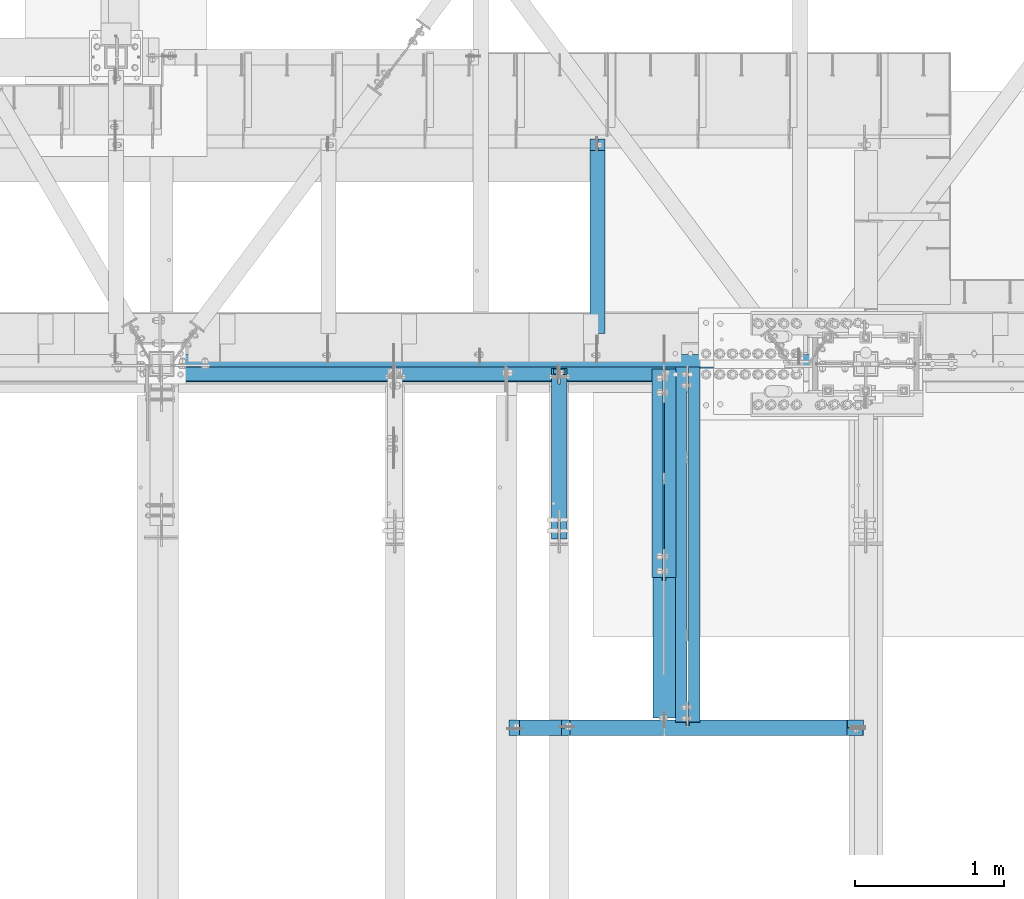
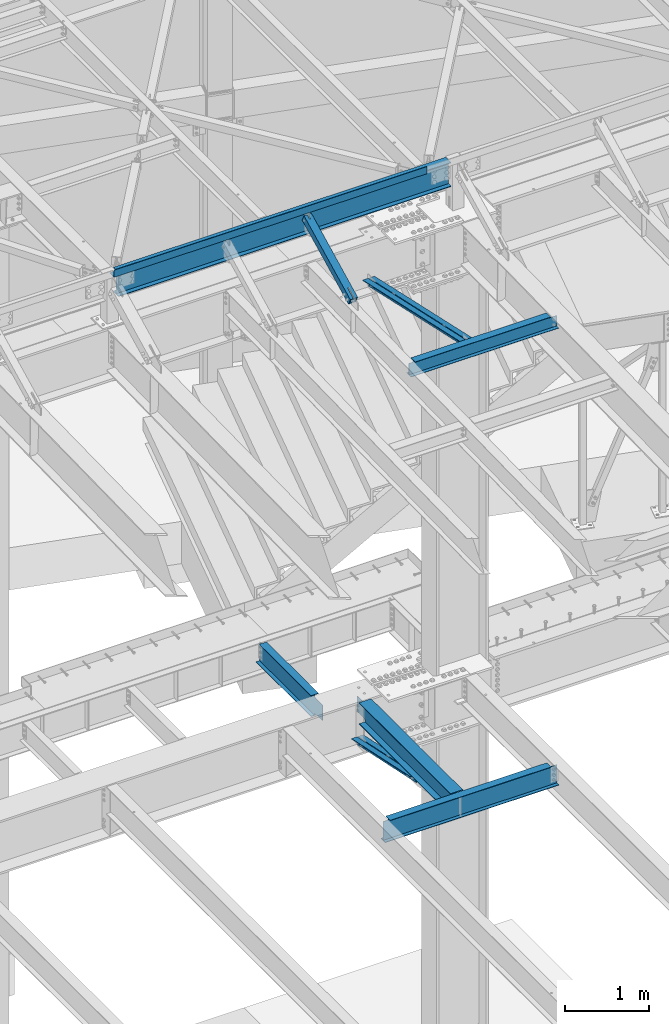
# One storey, part 1145 of 1763: 10 beams, 1 member, 8 elements without a shape of their own.
"""IFC2X3 building model written with IfcOpenShell, lengths in millimetres."""

from ifc_helpers import new_model, si_unit, frame, origin_with_axes, place, context, subcontext, project, spatial, faceted_brep, material, type_object, element, aggregate, save


model = new_model("IFC2X3")

# Units and contexts
model_context = context("Model", 3, precision=1e-05, world=origin_with_axes())
body_context = subcontext(model_context, "Body", "Model", "MODEL_VIEW")
ifc_project = project(units=[si_unit("LENGTHUNIT", "METRE", prefix="MILLI"), si_unit("AREAUNIT", "SQUARE_METRE"), si_unit("VOLUMEUNIT", "CUBIC_METRE"), si_unit("MASSUNIT", "GRAM", prefix="KILO"), si_unit("TIMEUNIT", "SECOND"), si_unit("PLANEANGLEUNIT", "RADIAN"), si_unit("SOLIDANGLEUNIT", "STERADIAN"), si_unit("THERMODYNAMICTEMPERATUREUNIT", "DEGREE_CELSIUS"), si_unit("LUMINOUSINTENSITYUNIT", "LUMEN")], contexts=[model_context])

# Site, building, storey
site_placement = place(None, origin_with_axes())
site = spatial("IfcSite", under=ifc_project, at=site_placement, CompositionType="ELEMENT")
building_placement = place(site_placement, origin_with_axes())
building = spatial("IfcBuilding", under=site, at=building_placement, Name="Undefined", CompositionType="ELEMENT")
storey_placement = place(building_placement, origin_with_axes())
storey = spatial("IfcBuildingStorey", under=building, at=storey_placement, Name="Undefined", CompositionType="ELEMENT", Elevation=0.0)

# Assembly, beam
assembly_1_placement = place(storey_placement, origin_with_axes())
assembly_1 = element("IfcElementAssembly", 1, at=assembly_1_placement, inside=storey, Name="BEAM", AssemblyPlace="NOTDEFINED", PredefinedType="RIGID_FRAME")
ifc_material_1 = material(Name="STEEL/A36")
beam_type_1 = type_object("IfcBeamType", Name="L4X4X1/4", PredefinedType="NOTDEFINED")
beam_1_placement = place(assembly_1_placement, frame((-39678.6396174442, 52050.9499994487, 12496.8), z_axis=(0.0, 1.0, 0.0), x_axis=(1.0, 0.0, 0.0)))
beam_1 = element("IfcBeam", 2, at=beam_1_placement, type_object=beam_type_1, material=ifc_material_1, Name="V. BRACE", ObjectType="L4X4X1/4", context=body_context, shape_type="Brep", body=[
    faceted_brep([(-3.63797880709171e-11, 50.8000000000011, -50.8000000000538), (-1.96450855582952e-10, 50.8000000000393, 50.7999999999374), (4273.54999999626, 50.7999999999993, 50.8000000000029), (4273.54999999626, 50.7999999999993, -50.8000000000029), (-1.81898940354586e-10, 44.4500000000371, 50.7999999999374), (4273.54999999626, 44.4500000000007, 50.8000000000029), (-2.18278728425503e-11, 44.4500000000007, -44.450000000048), (4273.54999999626, 44.4500000000007, -44.4499999999971), (1.96450855582952e-10, -50.8000000000338, -44.4499999999534), (4273.54999999626, -50.7999999999993, -44.4499999999971), (2.11002770811319e-10, -50.8000000000357, -50.799999999952), (4273.54999999626, -50.7999999999993, -50.8000000000029)], [[[0, 1, 2, 3]], [[1, 4, 5, 2]], [[4, 6, 7, 5]], [[6, 8, 9, 7]], [[8, 10, 11, 9]], [[10, 0, 3, 11]], [[5, 7, 9, 11, 3, 2]], [[10, 8, 6, 4, 1, 0]]]),
])

assembly_2_placement = place(storey_placement, origin_with_axes())
assembly_2 = element("IfcElementAssembly", 3, at=assembly_2_placement, inside=storey, Name="BEAM", AssemblyPlace="NOTDEFINED", PredefinedType="RIGID_FRAME")
ifc_material_2 = material(Name="STEEL/A992")
beam_type_2 = type_object("IfcBeamType", Name="W8X10", PredefinedType="NOTDEFINED")
beam_2_placement = place(assembly_2_placement, frame((-37006.0322886427, 49682.4, 11597.037837497), z_axis=(0.0, 0.0, 1.0), x_axis=(1.0, 0.0, 0.0)))
beam_2 = element("IfcBeam", 4, at=beam_2_placement, type_object=beam_type_2, material=ifc_material_2, Name="BEAM", ObjectType="W8X10", context=body_context, shape_type="Brep", body=[
    faceted_brep([(73.0250000000015, 2.38124999999854, 95.25), (73.0250000000015, 50.8000000000029, 95.25), (1929.98876494438, 50.8000000000029, 95.25), (1929.98876494438, 2.38124999999854, 95.25), (73.0250000000015, -50.8000000000029, 99.8647433179103), (73.0250000000015, 50.8000000000029, 100.012500000001), (73.0250000000015, 2.38124999999854, 80.7025014839273), (73.0250000000015, -2.38124999999854, 80.7025014839273), (73.0250000000015, -2.38124999999854, 95.25), (73.0250000000015, -50.8000000000029, 95.25), (72.0582700774103, 2.38124999999854, 75.8424219658809), (72.0582700774103, -2.38124999999854, 75.8424219658809), (69.3052561769364, 2.38124999999854, 71.7222454977273), (69.3052561769364, -2.38124999999854, 71.7222454977273), (65.1850797087827, 2.38124999999854, 68.9692315972497), (65.1850797087827, -2.38124999999854, 68.9692315972497), (60.3250001907363, 2.38124999999854, 68.0025016746622), (60.3250001907363, -2.38124999999854, 68.0025016746622), (15.875, -2.38124999999854, -95.25), (15.875, -7.31886096174276, -95.25), (15.875, -50.8000000000029, -95.25), (2037.93876494438, -50.8000000000029, -95.25), (2037.93876494438, -2.38124999999854, -95.25), (15.875, -50.8000000000029, -100.012500000001), (2037.93876494438, -50.8000000000029, -100.012500000001), (2037.93876494438, 2.38124999999854, -95.25), (2037.93876494438, 2.38124999999854, 55.3025016764987), (2037.93876494438, -2.38124999999854, 55.3025016764987), (2037.93876494438, 2.68122657429922, -100.012500000001), (2037.93876494438, 2.68141339288559, -95.25), (1937.8286852356, -2.38124999999854, 56.2692315990862), (1933.70850876745, -2.38124999999854, 59.0222454995637), (1930.95549486698, -2.38124999999854, 63.1424219677174), (1929.98876494438, -2.38124999999854, 68.0025014857638), (1929.98876494438, -2.38124999999854, 95.25), (15.875, -2.38124999999854, 68.0025016746622), (15.875, -2.38124999999854, -94.4899438370485), (1942.68876475365, -2.38124999999854, 55.3025016764987), (1929.98876494438, -50.8000000000029, 95.25), (1929.98876494438, -50.8000000000029, 100.004382425521), (1929.98876494438, 50.8000000000029, 100.012500000001), (1929.98876494438, 2.38124999999854, 68.0025014857638), (1930.95549486698, 2.38124999999854, 63.1424219677174), (1933.70850876745, 2.38124999999854, 59.0222454995637), (1937.8286852356, 2.38124999999854, 56.2692315990862), (1942.68876475365, 2.38124999999854, 55.3025016764987), (15.875, 2.38124999999854, -95.25), (15.875, 2.38124999999854, -94.4897249858841), (15.875, 2.38124999999854, 68.0025016746622), (15.875, 45.7998906187204, -95.25), (15.875, 50.8000000000029, -95.25), (15.875, 50.8000000000029, -100.012500000001), (15.875, 45.8001094698775, -100.012500000001), (15.875, -7.31864211058564, -100.012500000001), (1929.98869744366, 50.8000000000029, -100.012500000001), (1929.98872929847, 2.68115511105862, -100.012500000001), (1929.98872929833, 2.68134192965226, -95.25), (1929.98869744366, 50.8000000000029, -95.25)], [[[0, 1, 2, 3]], [[4, 5, 1, 0, 6, 7, 8, 9]], [[7, 6, 10, 11]], [[11, 10, 12, 13]], [[13, 12, 14, 15]], [[15, 14, 16, 17]], [[18, 19, 20, 21, 22]], [[20, 23, 24, 21]], [[25, 26, 27, 22, 21, 24, 28, 29]], [[30, 31, 32, 33, 34, 8, 7, 11, 13, 15, 17, 35, 36, 18, 22, 27, 37]], [[9, 8, 34, 38]], [[4, 9, 38, 39]], [[5, 4, 39, 40]], [[1, 5, 40, 2]], [[39, 38, 34, 33, 41, 3, 2, 40]], [[32, 42, 41, 33]], [[31, 43, 42, 32]], [[30, 44, 43, 31]], [[37, 45, 44, 30]], [[27, 26, 45, 37]], [[25, 46, 47, 48, 16, 14, 12, 10, 6, 0, 3, 41, 42, 43, 44, 45, 26]], [[17, 16, 48, 35]], [[47, 46, 49, 50, 51, 52, 53, 23, 20, 19, 18, 36, 35, 48]], [[24, 23, 53, 52, 51, 54, 55, 28]], [[29, 28, 55, 56]], [[57, 50, 49, 46, 25, 29, 56]], [[51, 50, 57, 54]], [[56, 55, 54, 57]]]),
])
aggregate(assembly_2, [beam_2])

# Assembly, member
assembly_3_placement = place(storey_placement, origin_with_axes())
assembly_3 = element("IfcElementAssembly", 5, at=assembly_3_placement, inside=storey, Name="BEAM", AssemblyPlace="NOTDEFINED", PredefinedType="RIGID_FRAME")
ifc_material_3 = material()
member_type = type_object("IfcMemberType", Name="HSS4X4X1/2", PredefinedType="NOTDEFINED")
member_placement = place(assembly_3_placement, frame((-37006.0322886427, 50822.4762408756, 11720.6381213764), z_axis=(-1.0, 0.0, 0.0), x_axis=(0.0, 0.894427191199916, 0.447213595099959)))
member = element("IfcMember", 6, at=member_placement, type_object=member_type, material=ifc_material_3, Name="BEAM", ObjectType="HSS4X4X1/2", context=body_context, shape_type="Brep", body=[
    faceted_brep([(1394.22226894295, -50.8000000020184, -7.9375), (1394.2222689429, -38.1000000020122, -7.9375), (1321.53025774739, -38.1000000019103, -7.9375), (1327.88025774027, -50.8000000019219, -7.9375), (1321.53025774739, -38.1000000019103, 7.9375), (1327.88025774027, -50.8000000019219, 7.9375), (1394.22226894295, -50.8000000020184, 7.9375), (1394.2222689429, -38.1000000020122, 7.9375), (1394.22226894266, 38.0999999980304, -7.9375), (1394.22226894262, 50.799999998042, -7.9375), (1277.08025779721, 50.7999999982076, -7.9375), (1283.4302577901, 38.0999999981887, -7.9375), (1277.08025779721, 50.7999999982076, 7.9375), (1283.4302577901, 38.0999999981887, 7.9375), (1394.22226894266, 38.0999999980304, 7.9375), (1394.22226894262, 50.799999998042, 7.9375), (166.342448712407, -38.100000000255, 38.0999999999985), (166.342448712276, 38.0999999997875, 38.0999999999985), (1394.22226894266, 38.0999999980304, 38.0999999999985), (1394.2222689429, -38.1000000020122, 38.0999999999985), (1394.2222689429, -38.1000000020122, -38.0999999999985), (166.342448712407, -38.100000000255, -38.0999999999985), (166.342448712407, -38.100000000255, -7.93749999974898), (317.154945941751, -38.1000000004715, -7.93749999987267), (320.192495686126, -38.1000000004769, -7.33329378918279), (322.767606017376, -38.1000000004806, -5.61266007554514), (324.488239731007, -38.1000000004842, -3.03754974427284), (325.092445941693, -38.1000000004842, 2.5465851649642e-10), (324.488239731007, -38.1000000004842, 3.03754974465119), (322.767606017376, -38.1000000004806, 5.61266007592349), (320.192495686126, -38.1000000004788, 7.33329378956478), (317.154945941751, -38.1000000004733, 7.93750000025466), (166.342448712407, -38.100000000255, 7.93750000025466), (166.342448712276, 38.0999999997875, -38.0999999999985), (1394.22226894266, 38.0999999980304, -38.0999999999985), (166.342448712276, 38.0999999997875, 7.93750000025466), (166.342448712254, 50.7999999997955, 7.93750000025466), (317.154945941591, 50.7999999995791, 7.93750000025466), (317.15494594162, 38.0999999995711, 7.93750000025466), (320.192495685966, 50.7999999995736, 7.33329378956478), (320.192495685995, 38.0999999995693, 7.33329378956478), (322.767606017216, 50.7999999995718, 5.61266007592349), (322.767606017245, 38.0999999995638, 5.61266007592349), (324.488239730847, 50.7999999995682, 3.03754974465119), (324.488239730868, 38.0999999995638, 3.03754974465119), (325.092445941533, 50.7999999995682, 2.5465851649642e-10), (325.092445941555, 38.0999999995583, 2.5465851649642e-10), (324.488239730847, 50.7999999995682, -3.03754974427284), (324.488239730861, 38.0999999995602, -3.03754974427284), (322.767606017209, 50.79999999957, -5.61266007554514), (322.767606017245, 38.0999999995638, -5.61266007554514), (320.192495685966, 50.7999999995754, -7.33329378918279), (320.19249568598, 38.0999999995674, -7.33329378918279), (317.154945941591, 50.7999999995791, -7.93749999987267), (317.154945941606, 38.0999999995693, -7.93749999987267), (166.342448712254, 50.7999999997955, -7.93749999974898), (166.342448712276, 38.0999999997875, -7.93749999974898), (166.342448712254, 50.7999999997955, -50.7999999999993), (166.342448712421, -50.8000000002612, -50.7999999999993), (166.342448712421, -50.8000000002612, -7.93749999974898), (317.154945941773, -50.8000000004795, -7.93749999987267), (320.192495686155, -50.8000000004831, -7.33329378918279), (322.767606017391, -50.8000000004868, -5.61266007554514), (324.488239731028, -50.800000000494, -3.03754974427284), (325.092445941715, -50.8000000004904, 2.5465851649642e-10), (324.488239731028, -50.800000000494, 3.03754974465119), (322.767606017405, -50.8000000004849, 5.61266007592349), (320.192495686155, -50.8000000004849, 7.33329378956478), (317.154945941787, -50.8000000004795, 7.93750000025466), (166.342448712421, -50.8000000002612, 7.93750000025466), (166.342448712421, -50.8000000002612, 50.7999999999993), (166.342448712254, 50.7999999997955, 50.7999999999993), (1394.22226894295, -50.8000000020184, 50.7999999999993), (1394.22226894262, 50.799999998042, 50.7999999999993), (1394.22226894262, 50.799999998042, -50.7999999999993), (1394.22226894295, -50.8000000020184, -50.7999999999993)], [[[0, 1, 2, 3]], [[3, 2, 4, 5]], [[6, 5, 4, 7]], [[8, 9, 10, 11]], [[11, 10, 12, 13]], [[14, 13, 12, 15]], [[16, 17, 18, 19]], [[2, 1, 20, 21, 22, 23, 24, 25, 26, 27, 28, 29, 30, 31, 32, 16, 19, 7, 4]], [[33, 21, 20, 34]], [[35, 36, 37, 38]], [[38, 37, 39, 40]], [[40, 39, 41, 42]], [[42, 41, 43, 44]], [[44, 43, 45, 46]], [[46, 45, 47, 48]], [[48, 47, 49, 50]], [[50, 49, 51, 52]], [[52, 51, 53, 54]], [[54, 53, 55, 56]], [[21, 33, 56, 55, 57, 58, 59, 22]], [[60, 23, 22, 59]], [[61, 24, 23, 60]], [[62, 25, 24, 61]], [[63, 26, 25, 62]], [[64, 27, 26, 63]], [[65, 28, 27, 64]], [[66, 29, 28, 65]], [[67, 30, 29, 66]], [[68, 31, 30, 67]], [[69, 32, 31, 68]], [[70, 71, 36, 35, 17, 16, 32, 69]], [[71, 70, 72, 73]], [[19, 18, 14, 15, 73, 72, 6, 7]], [[10, 9, 74, 57, 55, 53, 51, 49, 47, 45, 43, 41, 39, 37, 36, 71, 73, 15, 12]], [[58, 57, 74, 75]], [[72, 70, 69, 68, 67, 66, 65, 64, 63, 62, 61, 60, 59, 58, 75, 0, 3, 5, 6]], [[75, 74, 9, 8, 34, 20, 1, 0]], [[18, 17, 35, 38, 40, 42, 44, 46, 48, 50, 52, 54, 56, 33, 34, 8, 11, 13, 14]]]),
])
aggregate(assembly_3, [member])

# Beam
beam_type_3 = type_object("IfcBeamType", Name="W14X22", PredefinedType="NOTDEFINED")
beam_3_placement = place(assembly_1_placement, frame((-39672.2896174427, 52120.7999997282, 12271.375), z_axis=(0.0, 0.0, 1.0), x_axis=(1.0, 0.0, 0.0)))
beam_3 = element("IfcBeam", 7, at=beam_3_placement, type_object=beam_type_3, material=ifc_material_2, Name="BEAM", ObjectType="W14X22", context=body_context, shape_type="Brep", body=[
    faceted_brep([(88.8999999999942, 63.5, -174.625), (88.8999999999942, 63.5, -166.6875), (4633.55234374577, 63.5, -166.6875), (4633.55234374577, 63.5, -174.625), (88.8999999999942, 3.17500000000291, -166.6875), (4633.55234374577, 3.17500000000291, -166.6875), (88.8999999999942, 3.17500000000291, 166.6875), (4633.55234374577, 3.17500000000291, 166.6875), (88.8999999999942, 63.5, 166.6875), (4633.55234374577, 63.5, 166.6875), (88.8999999999942, 63.5, 174.625), (4633.55234374577, 63.5, 174.625), (88.8999999999942, -63.5, 174.625), (4633.55234374577, -63.5, 174.625), (88.8999999999942, -63.5, 166.6875), (4633.55234374577, -63.5, 166.6875), (88.8999999999942, -3.17500000000291, 166.6875), (4633.55234374577, -3.17500000000291, 166.6875), (88.8999999999942, -3.17500000000291, -166.6875), (4633.55234374577, -3.17500000000291, -166.6875), (88.8999999999942, -63.5, -166.6875), (4633.55234374577, -63.5, -166.6875), (88.8999999999942, -63.5, -174.625), (4633.55234374577, -63.5, -174.625)], [[[0, 1, 2, 3]], [[1, 4, 5, 2]], [[4, 6, 7, 5]], [[6, 8, 9, 7]], [[8, 10, 11, 9]], [[10, 12, 13, 11]], [[12, 14, 15, 13]], [[14, 16, 17, 15]], [[16, 18, 19, 17]], [[18, 20, 21, 19]], [[20, 22, 23, 21]], [[22, 0, 3, 23]], [[5, 7, 9, 11, 13, 15, 17, 19, 21, 23, 3, 2]], [[22, 20, 18, 16, 14, 12, 10, 8, 6, 4, 1, 0]]]),
])

aggregate(assembly_1, [beam_1, beam_3])

# Assembly, beams
assembly_4_placement = place(storey_placement, origin_with_axes())
assembly_4 = element("IfcElementAssembly", 8, at=assembly_4_placement, inside=storey, Name="ANGLE BRACE", AssemblyPlace="NOTDEFINED", PredefinedType="RIGID_FRAME")
beam_type_4 = type_object("IfcBeamType", Name="L4X3X5/16", PredefinedType="NOTDEFINED")
beam_4_placement = place(assembly_4_placement, frame((-36346.8372736984, 50680.4564530846, 4820.75267554856), z_axis=(0.0, -0.2072236520035, -0.978293595016513), x_axis=(0.0, 0.978293600950479, -0.20722362398951)))
beam_4 = element("IfcBeam", 9, at=beam_4_placement, type_object=beam_type_4, material=ifc_material_1, Name="ANGLE BRACE", ObjectType="L4X3X5/16", context=body_context, shape_type="Brep", body=[
    faceted_brep([(1.45519152283669e-10, 38.0999999999985, -50.7999999999993), (1.45519152283669e-10, 38.0999999999985, 50.7999999999993), (1427.42255777739, 38.0999999999985, 50.7999999995518), (1427.42255777754, 38.0999999999985, -50.8000000004868), (-7.27595761418343e-11, 30.1624999999985, 50.8000000000211), (1427.42255777739, 30.1624999999985, 50.7999999995518), (7.27595761418343e-11, 30.1624999999985, -42.8625000000175), (1427.42255777754, 30.1624999999985, -42.8625000004868), (7.27595761418343e-11, -38.0999999999985, -42.8625000000175), (1427.42255777754, -38.0999999999985, -42.8625000004868), (-1.23691279441118e-10, -38.1000000000022, -50.7999999999993), (1427.42255777754, -38.0999999999985, -50.8000000004868)], [[[0, 1, 2, 3]], [[1, 4, 5, 2]], [[4, 6, 7, 5]], [[6, 8, 9, 7]], [[8, 10, 11, 9]], [[10, 0, 3, 11]], [[5, 7, 9, 11, 3, 2]], [[10, 8, 6, 4, 1, 0]]]),
])
beam_5_placement = place(assembly_4_placement, frame((-36261.1122736983, 52076.9355387112, 4524.94833056974), z_axis=(0.0, -0.2072236520035, -0.978293595016513), x_axis=(0.0, -0.978293595016513, 0.207223652003498)))
beam_5 = element("IfcBeam", 10, at=beam_5_placement, type_object=beam_type_4, material=ifc_material_1, Name="ANGLE BRACE", ObjectType="L4X3X5/16", context=body_context, shape_type="Brep", body=[
    faceted_brep([(1.45519152283669e-10, 38.0999999999985, -50.7999999999993), (1.45519152283669e-10, 38.0999999999985, 50.7999999999993), (1427.46422513096, 38.0999999999985, 50.7999999991189), (1427.46422513096, 38.0999999999985, -50.8000000008396), (-7.27595761418343e-11, 30.1624999999985, 50.8000000000211), (1427.46422513096, 30.1624999999985, 50.7999999991189), (7.27595761418343e-11, 30.1624999999985, -42.8625000000175), (1427.46422513096, 30.1624999999985, -42.8625000008433), (7.27595761418343e-11, -38.0999999999985, -42.8625000000175), (1427.46422513096, -38.0999999999985, -42.8625000008433), (-1.23691279441118e-10, -38.1000000000022, -50.7999999999993), (1427.46422513096, -38.0999999999985, -50.8000000008396)], [[[0, 1, 2, 3]], [[1, 4, 5, 2]], [[4, 6, 7, 5]], [[6, 8, 9, 7]], [[8, 10, 11, 9]], [[10, 0, 3, 11]], [[5, 7, 9, 11, 3, 2]], [[10, 8, 6, 4, 1, 0]]]),
])
aggregate(assembly_4, [beam_4, beam_5])

assembly_5_placement = place(storey_placement, origin_with_axes())
assembly_5 = element("IfcElementAssembly", 11, at=assembly_5_placement, inside=storey, Name="V. BRACE", AssemblyPlace="NOTDEFINED", PredefinedType="RIGID_FRAME")
beam_6_placement = place(assembly_5_placement, frame((-36187.5581070317, 49682.4000008043, 11620.850337497), z_axis=(0.0, -0.216256452978334, -0.976336594902204), x_axis=(0.0, 0.976336594902204, -0.216256452978331)))
beam_6 = element("IfcBeam", 12, at=beam_6_placement, type_object=beam_type_4, material=ifc_material_1, Name="V. BRACE", ObjectType="L4X3X5/16", context=body_context, shape_type="Brep", body=[
    faceted_brep([(26.6988622369681, 38.0999999999985, -50.799999999992), (26.698862236939, 38.0999999999985, 50.8000000000065), (2465.1027759838, 38.0999999999985, 50.800000000705), (2465.10955767961, 38.0999999999985, -50.7999999992899), (26.698862236939, 30.1624999999985, 50.8000000000065), (2465.1027759838, 30.1624999999985, 50.800000000705), (26.6988622369681, 30.1624999999985, -42.862499999992), (2465.10902785963, 30.1624999999985, -42.8624999992899), (26.6988622369681, -38.0999999999985, -42.862499999992), (2465.10902785963, -38.0999999999985, -42.8624999992899), (26.6988622369681, -38.0999999999985, -50.799999999992), (2465.10955767961, -38.0999999999985, -50.7999999992899)], [[[0, 1, 2, 3]], [[1, 4, 5, 2]], [[4, 6, 7, 5]], [[6, 8, 9, 7]], [[8, 10, 11, 9]], [[10, 0, 3, 11]], [[5, 7, 9, 11, 3, 2]], [[10, 8, 6, 4, 1, 0]]]),
])
beam_7_placement = place(assembly_5_placement, frame((-36101.8331069916, 52120.8, 11080.749989399), z_axis=(0.0, -0.216256452978334, -0.976336594902204), x_axis=(0.0, -0.976336594902203, 0.216256452978338)))
beam_7 = element("IfcBeam", 13, at=beam_7_placement, type_object=beam_type_4, material=ifc_material_1, Name="V. BRACE", ObjectType="L4X3X5/16", context=body_context, shape_type="Brep", body=[
    faceted_brep([(32.3897800854102, 38.0999999999985, -50.8000000000065), (32.396561781221, 38.0999999999985, 50.799999999992), (2470.80047552809, 38.0999999999985, 50.7999999992862), (2470.80047552806, 38.0999999999985, -50.8000000007123), (32.396561781221, 30.1624999999985, 50.799999999992), (2470.80047552809, 30.1624999999985, 50.7999999992862), (32.3903099053932, 30.1624999999985, -42.8625000000065), (2470.80047552806, 30.1624999999985, -42.8625000007123), (32.3903099053932, -38.0999999999985, -42.8625000000065), (2470.80047552806, -38.0999999999985, -42.8625000007123), (32.3897800854102, -38.0999999999985, -50.8000000000065), (2470.80047552806, -38.0999999999985, -50.8000000007123)], [[[0, 1, 2, 3]], [[1, 4, 5, 2]], [[4, 6, 7, 5]], [[6, 8, 9, 7]], [[8, 10, 11, 9]], [[10, 0, 3, 11]], [[5, 7, 9, 11, 3, 2]], [[10, 8, 6, 4, 1, 0]]]),
])
aggregate(assembly_5, [beam_6, beam_7])

# Assembly, beam
assembly_6_placement = place(storey_placement, origin_with_axes())
assembly_6 = element("IfcElementAssembly", 14, at=assembly_6_placement, inside=storey, Name="BEAM", AssemblyPlace="NOTDEFINED", PredefinedType="RIGID_FRAME")
beam_type_5 = type_object("IfcBeamType", Name="W12X16", PredefinedType="NOTDEFINED")
beam_8_placement = place(assembly_6_placement, frame((-36748.408627365, 52120.8, 5041.9), z_axis=(0.0, 0.0, 1.0), x_axis=(0.0, 1.0, 0.0)))
beam_8 = element("IfcBeam", 15, at=beam_8_placement, type_object=beam_type_5, material=ifc_material_2, Name="BEAM", ObjectType="W12X16", context=body_context, shape_type="Brep", body=[
    faceted_brep([(20.6374999999971, -3.17500000000291, -114.3), (20.6374999999971, 3.17500000000291, -114.3), (192.087500190733, 3.17500000000291, -114.3), (192.087500190733, -3.17500000000291, -114.3), (196.94757970878, 3.17500000000291, -115.266729922588), (196.94757970878, -3.17500000000291, -115.266729922588), (201.067756176933, 3.17500000000291, -118.019743823066), (201.067756176933, -3.17500000000291, -118.019743823066), (203.820770077407, 3.17500000000291, -122.13992029122), (203.820770077407, -3.17500000000291, -122.13992029122), (204.787499999999, -3.17500000000291, -126.999999809265), (204.787499999999, 3.17500000000291, -126.999999809265), (204.787499999999, 3.17500000000291, -146.05), (204.787499999999, 50.8000000000029, -146.05), (204.787499999999, 50.8000000000029, -152.4), (204.787499999999, -50.8000000000029, -152.4), (204.787499999999, -50.8000000000029, -146.05), (204.787499999999, -3.17500000000291, -146.05), (1431.13125000001, 50.8000000000029, 146.05), (1431.13125000001, 3.17500000000291, 146.05), (204.787499999999, 3.17500000000291, 146.05), (204.787499999999, 50.8000000000029, 146.05), (192.087500190733, -3.17500000000291, 114.3), (192.087500190733, 3.17500000000291, 114.3), (20.6374999999971, 3.17500000000291, 114.3), (20.6374999999971, -3.17500000000291, 114.3), (196.94757970878, -3.17500000000291, 115.266729922588), (196.94757970878, 3.17500000000291, 115.266729922588), (201.067756176933, -3.17500000000291, 118.019743823066), (201.067756176933, 3.17500000000291, 118.019743823066), (203.820770077407, -3.17500000000291, 122.13992029122), (203.820770077407, 3.17500000000291, 122.13992029122), (204.787499999999, -3.17500000000291, 126.999999809265), (204.787499999999, 3.17500000000291, 126.999999809265), (1431.13125000001, -50.8000000000029, 152.4), (1431.13125000001, 50.8000000000029, 152.4), (204.787499999999, 50.8000000000029, 152.4), (204.787499999999, -50.8000000000029, 152.4), (1431.13125000001, -50.8000000000029, 146.05), (204.787499999999, -50.8000000000029, 146.05), (1431.13125000001, -3.17500000000291, 146.05), (204.787499999999, -3.17500000000291, 146.05), (1431.13125000001, -3.17500000000291, 139.440001487732), (1431.13125000001, 3.17500000000291, 139.440001487732), (1432.0979799226, -3.17500000000291, 134.579921969686), (1432.0979799226, 3.17500000000291, 134.579921969686), (1434.85099382307, -3.17500000000291, 130.459745501533), (1434.85099382307, 3.17500000000291, 130.459745501533), (1438.97117029122, -3.17500000000291, 127.706731601054), (1438.97117029122, 3.17500000000291, 127.706731601054), (1443.83124980927, -3.17500000000291, 126.740001678467), (1443.83124980927, 3.17500000000291, 126.740001678467), (1507.33125, -3.17500000000291, 126.740001678467), (1507.33125, 3.17500000000291, 126.740001678467), (1507.33125, -3.17500000000291, -146.05), (1507.33125, -50.8000000000029, -146.05), (1507.33125, -50.8000000000029, -152.4), (1507.33125, 50.8000000000029, -152.4), (1507.33125, 50.8000000000029, -146.05), (1507.33125, 3.17500000000291, -146.05)], [[[0, 1, 2, 3]], [[3, 2, 4, 5]], [[5, 4, 6, 7]], [[7, 6, 8, 9]], [[10, 11, 12, 13, 14, 15, 16, 17]], [[9, 8, 11, 10]], [[18, 19, 20, 21]], [[22, 23, 24, 25]], [[26, 27, 23, 22]], [[28, 29, 27, 26]], [[30, 31, 29, 28]], [[32, 33, 31, 30]], [[34, 35, 36, 37]], [[38, 34, 37, 39]], [[40, 38, 39, 41]], [[37, 36, 21, 20, 33, 32, 41, 39]], [[35, 18, 21, 36]], [[34, 38, 40, 42, 43, 19, 18, 35]], [[44, 45, 43, 42]], [[46, 47, 45, 44]], [[48, 49, 47, 46]], [[50, 51, 49, 48]], [[52, 53, 51, 50]], [[54, 55, 56, 57, 58, 59, 53, 52]], [[55, 54, 17, 16]], [[56, 55, 16, 15]], [[57, 56, 15, 14]], [[58, 57, 14, 13]], [[59, 58, 13, 12]], [[6, 4, 2, 1, 24, 23, 27, 29, 31, 33, 20, 19, 43, 45, 47, 49, 51, 53, 59, 12, 11, 8]], [[25, 24, 1, 0]], [[54, 52, 50, 48, 46, 44, 42, 40, 41, 32, 30, 28, 26, 22, 25, 0, 3, 5, 7, 9, 10, 17]]]),
])
aggregate(assembly_6, [beam_8])

assembly_7_placement = place(storey_placement, origin_with_axes())
assembly_7 = element("IfcElementAssembly", 16, at=assembly_7_placement, inside=storey, Name="BEAM", AssemblyPlace="NOTDEFINED", PredefinedType="RIGID_FRAME")
beam_type_6 = type_object("IfcBeamType", Name="W12X26", PredefinedType="NOTDEFINED")
beam_9_placement = place(assembly_7_placement, frame((-36296.0372736983, 49682.4, 5038.725), z_axis=(0.0, 0.0, 1.0), x_axis=(0.0, 1.0, 0.0)))
beam_9 = element("IfcBeam", 17, at=beam_9_placement, type_object=beam_type_6, material=ifc_material_2, Name="BEAM", ObjectType="W12X26", context=body_context, shape_type="Brep", body=[
    faceted_brep([(2233.6125, -3.17500000000291, -146.05), (2233.6125, -82.5500000000029, -146.05), (2233.6125, -82.5500000000029, -155.575), (2233.6125, 82.5500000000029, -155.575), (2233.6125, 82.5500000000029, -146.05), (2233.6125, 3.17500000000291, -146.05), (2233.6125, 3.17500000000291, -123.824999809265), (2233.6125, -3.17500000000291, -123.824999809265), (2234.57922992259, 3.17500000000291, -118.96492029122), (2234.57922992259, -3.17500000000291, -118.96492029122), (2237.33224382307, 3.17500000000291, -114.844743823066), (2237.33224382307, -3.17500000000291, -114.844743823066), (2241.45242029122, 3.17500000000291, -112.091729922588), (2241.45242029122, -3.17500000000291, -112.091729922588), (2246.31249980927, 3.17500000000291, -111.125), (2246.31249980927, -3.17500000000291, -111.125), (2417.7625, -3.17500000000291, -111.125), (2417.7625, 3.17500000000291, -111.125), (65.8812499999913, 3.17500000000291, 146.05), (65.8812499999913, 82.5500000000029, 146.05), (2233.6125, 82.5500000000029, 146.05), (2233.6125, 3.17500000000291, 146.05), (65.8812499999913, -3.17500000000291, -123.824999809265), (65.8812499999913, 3.17500000000291, -123.824999809265), (65.8812499999913, 3.17500000000291, -146.05), (65.8812499999913, 82.5500000000029, -146.05), (65.8812499999913, 82.5500000000029, -155.575), (65.8812499999913, -82.5500000000029, -155.575), (65.8812499999913, -82.5500000000029, -146.05), (65.8812499999913, -3.17500000000291, -146.05), (64.9145200774001, -3.17500000000291, -118.96492029122), (64.9145200774001, 3.17500000000291, -118.96492029122), (62.1615061769262, -3.17500000000291, -114.844743823066), (62.1615061769262, 3.17500000000291, -114.844743823066), (58.0413297087725, -3.17500000000291, -112.091729922588), (58.0413297087725, 3.17500000000291, -112.091729922588), (53.1812501907261, -3.17500000000291, -111.125), (53.1812501907261, 3.17500000000291, -111.125), (15.0812499999956, -3.17500000000291, -111.125), (15.0812499999956, 3.17500000000291, -111.125), (15.0812499999956, -3.17500000000291, 117.475), (15.0812499999956, 3.17500000000291, 117.475), (53.1812501907261, -3.17500000000291, 117.475), (53.1812501907261, 3.17500000000291, 117.475), (58.0413297087725, -3.17500000000291, 118.441729922588), (58.0413297087725, 3.17500000000291, 118.441729922588), (62.1615061769262, -3.17500000000291, 121.194743823066), (62.1615061769262, 3.17500000000291, 121.194743823066), (64.9145200774001, -3.17500000000291, 125.31492029122), (64.9145200774001, 3.17500000000291, 125.31492029122), (65.8812499999913, -3.17500000000291, 130.174999809266), (65.8812499999913, 3.17500000000291, 130.174999809266), (65.8812499999913, -82.5500000000029, 155.575), (65.8812499999913, 82.5500000000029, 155.575), (65.8812499999913, -3.17500000000291, 146.05), (65.8812499999913, -82.5500000000029, 146.05), (2233.6125, -3.17500000000291, 146.05), (2233.6125, -82.5500000000029, 146.05), (2233.6125, -82.5500000000029, 155.575), (2233.6125, 82.5500000000029, 155.575), (2233.6125, -3.17500000000291, 123.824999809265), (2233.6125, 3.17500000000291, 123.824999809265), (2234.57922992259, -3.17500000000291, 118.96492029122), (2234.57922992259, 3.17500000000291, 118.96492029122), (2237.33224382307, -3.17500000000291, 114.844743823066), (2237.33224382307, 3.17500000000291, 114.844743823066), (2241.45242029122, -3.17500000000291, 112.091729922588), (2241.45242029122, 3.17500000000291, 112.091729922588), (2246.31249980927, -3.17500000000291, 111.125), (2246.31249980927, 3.17500000000291, 111.125), (2417.7625, -3.17500000000291, 111.125), (2417.7625, 3.17500000000291, 111.125)], [[[0, 1, 2, 3, 4, 5, 6, 7]], [[7, 6, 8, 9]], [[9, 8, 10, 11]], [[11, 10, 12, 13]], [[13, 12, 14, 15]], [[16, 15, 14, 17]], [[18, 19, 20, 21]], [[22, 23, 24, 25, 26, 27, 28, 29]], [[30, 31, 23, 22]], [[32, 33, 31, 30]], [[34, 35, 33, 32]], [[36, 37, 35, 34]], [[38, 39, 37, 36]], [[40, 41, 39, 38]], [[42, 43, 41, 40]], [[44, 45, 43, 42]], [[46, 47, 45, 44]], [[48, 49, 47, 46]], [[50, 51, 49, 48]], [[52, 53, 19, 18, 51, 50, 54, 55]], [[55, 54, 56, 57]], [[52, 55, 57, 58]], [[53, 52, 58, 59]], [[19, 53, 59, 20]], [[58, 57, 56, 60, 61, 21, 20, 59]], [[62, 63, 61, 60]], [[64, 65, 63, 62]], [[66, 67, 65, 64]], [[68, 69, 67, 66]], [[70, 71, 69, 68]], [[71, 70, 16, 17]], [[12, 10, 8, 6, 5, 24, 23, 31, 33, 35, 37, 39, 41, 43, 45, 47, 49, 51, 18, 21, 61, 63, 65, 67, 69, 71, 17, 14]], [[25, 24, 5, 4]], [[26, 25, 4, 3]], [[27, 26, 3, 2]], [[28, 27, 2, 1]], [[29, 28, 1, 0]], [[70, 68, 66, 64, 62, 60, 56, 54, 50, 48, 46, 44, 42, 40, 38, 36, 34, 32, 30, 22, 29, 0, 7, 9, 11, 13, 15, 16]]]),
])
aggregate(assembly_7, [beam_9])

assembly_8_placement = place(storey_placement, origin_with_axes())
assembly_8 = element("IfcElementAssembly", 18, at=assembly_8_placement, inside=storey, Name="BEAM", AssemblyPlace="NOTDEFINED", PredefinedType="RIGID_FRAME")
beam_type_7 = type_object("IfcBeamType", Name="W12X14", PredefinedType="NOTDEFINED")
beam_10_placement = place(assembly_8_placement, frame((-37358.603940365, 49682.4, 5043.4875), z_axis=(0.0, 0.0, 1.0), x_axis=(1.0, 0.0, 0.0)))
beam_10 = element("IfcBeam", 19, at=beam_10_placement, type_object=beam_type_7, material=ifc_material_2, Name="BEAM", ObjectType="W12X14", context=body_context, shape_type="Brep", body=[
    faceted_brep([(2284.14791666668, -50.8000000000029, 150.8125), (2284.14791666668, -50.8000000000029, 144.4625), (2284.14791666668, -2.38124999999854, 144.4625), (2284.14791666668, -2.38124999999854, 131.502501487732), (2284.14791666668, 2.38124999999854, 131.502501487732), (2284.14791666668, 2.38124999999854, 144.4625), (2284.14791666668, 50.8000000000029, 144.4625), (2284.14791666668, 50.8000000000029, 150.8125), (2285.11464658927, -2.38124999999854, 126.642421969686), (2285.11464658927, 2.38124999999854, 126.642421969686), (2287.86766048974, -2.38124999999854, 122.522245501533), (2287.86766048974, 2.38124999999854, 122.522245501533), (2291.98783695789, -2.38124999999854, 119.769231601054), (2291.98783695789, 2.38124999999854, 119.769231601054), (2296.84791647594, -2.38124999999854, 118.802501678467), (2296.84791647594, 2.38124999999854, 118.802501678467), (2392.09791666667, -2.38124999999854, 118.802501678467), (2392.09791666667, 2.38124999999854, 118.802501678467), (85.724999999984, -50.8000000000029, 150.8125), (85.724999999984, 50.8000000000029, 150.8125), (85.724999999984, 50.8000000000029, 144.4625), (85.724999999984, 2.38124999999854, 144.4625), (85.724999999984, 2.38124999999854, 137.852501487731), (85.724999999984, -2.38124999999854, 137.852501487731), (85.724999999984, -2.38124999999854, 144.4625), (85.724999999984, -50.8000000000029, 144.4625), (84.7582700773928, 2.38124999999854, 132.992421969686), (84.7582700773928, -2.38124999999854, 132.992421969686), (82.0052561769189, 2.38124999999854, 128.872245501532), (82.0052561769189, -2.38124999999854, 128.872245501532), (77.8850797087653, 2.38124999999854, 126.119231601054), (77.8850797087653, -2.38124999999854, 126.119231601054), (73.0250001907189, 2.38124999999854, 125.152501678466), (73.0250001907189, -2.38124999999854, 125.152501678466), (15.875, 2.38124999999854, 125.152501678466), (15.875, -2.38124999999854, 125.152501678466), (15.875, 2.38124999999854, -144.4625), (15.875, 50.8000000000029, -144.4625), (15.875, 50.8000000000029, -150.8125), (15.875, -50.8000000000029, -150.8125), (15.875, -50.8000000000029, -144.4625), (15.875, -2.38124999999854, -144.4625), (2392.09791666667, 2.38124999999854, -144.4625), (2392.09791666667, 50.8000000000029, -144.4625), (2392.09791666667, 50.8000000000029, -150.8125), (2392.09791666667, -50.8000000000029, -150.8125), (2392.09791666667, -50.8000000000029, -144.4625), (2392.09791666667, -2.38124999999854, -144.4625)], [[[0, 1, 2, 3, 4, 5, 6, 7]], [[8, 9, 4, 3]], [[10, 11, 9, 8]], [[12, 13, 11, 10]], [[14, 15, 13, 12]], [[16, 17, 15, 14]], [[18, 19, 20, 21, 22, 23, 24, 25]], [[23, 22, 26, 27]], [[27, 26, 28, 29]], [[29, 28, 30, 31]], [[31, 30, 32, 33]], [[33, 32, 34, 35]], [[36, 37, 38, 39, 40, 41, 35, 34]], [[37, 36, 42, 43]], [[38, 37, 43, 44]], [[39, 38, 44, 45]], [[40, 39, 45, 46]], [[41, 40, 46, 47]], [[12, 10, 8, 3, 2, 24, 23, 27, 29, 31, 33, 35, 41, 47, 16, 14]], [[25, 24, 2, 1]], [[18, 25, 1, 0]], [[19, 18, 0, 7]], [[20, 19, 7, 6]], [[21, 20, 6, 5]], [[42, 36, 34, 32, 30, 28, 26, 22, 21, 5, 4, 9, 11, 13, 15, 17]], [[47, 46, 45, 44, 43, 42, 17, 16]]]),
])
aggregate(assembly_8, [beam_10])

save(model, "model.ifc")
